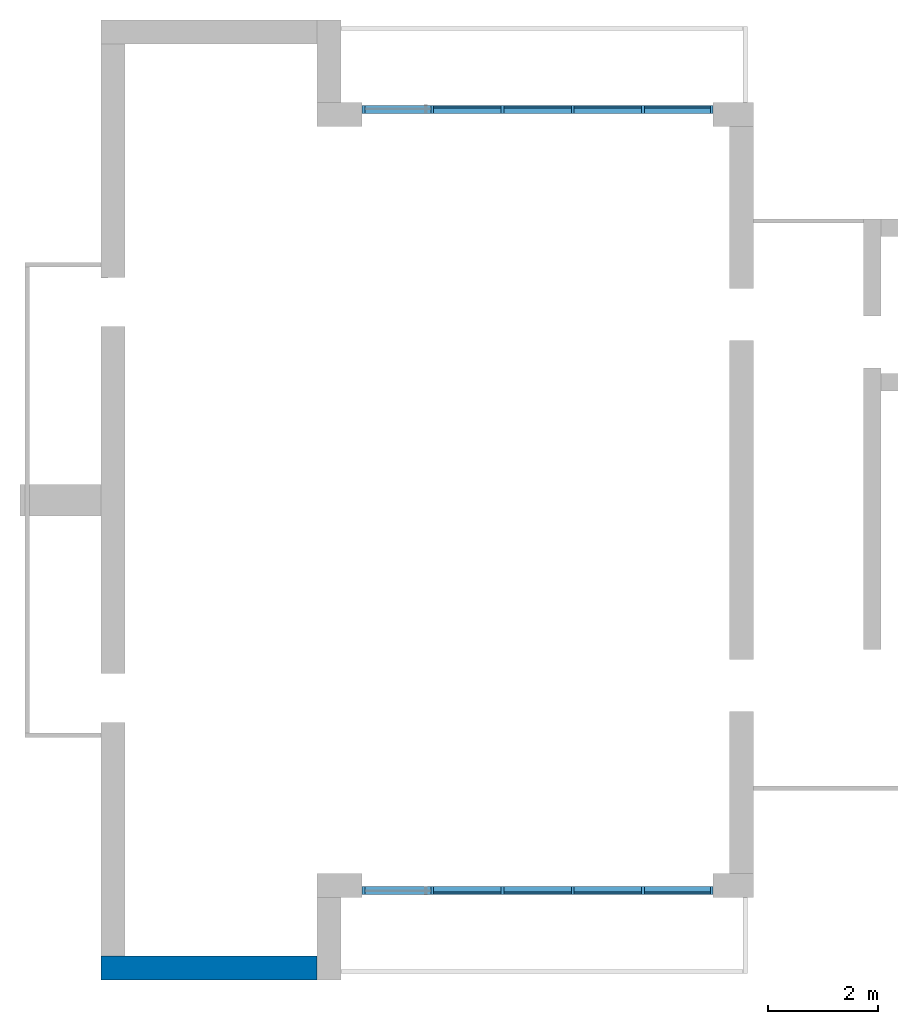
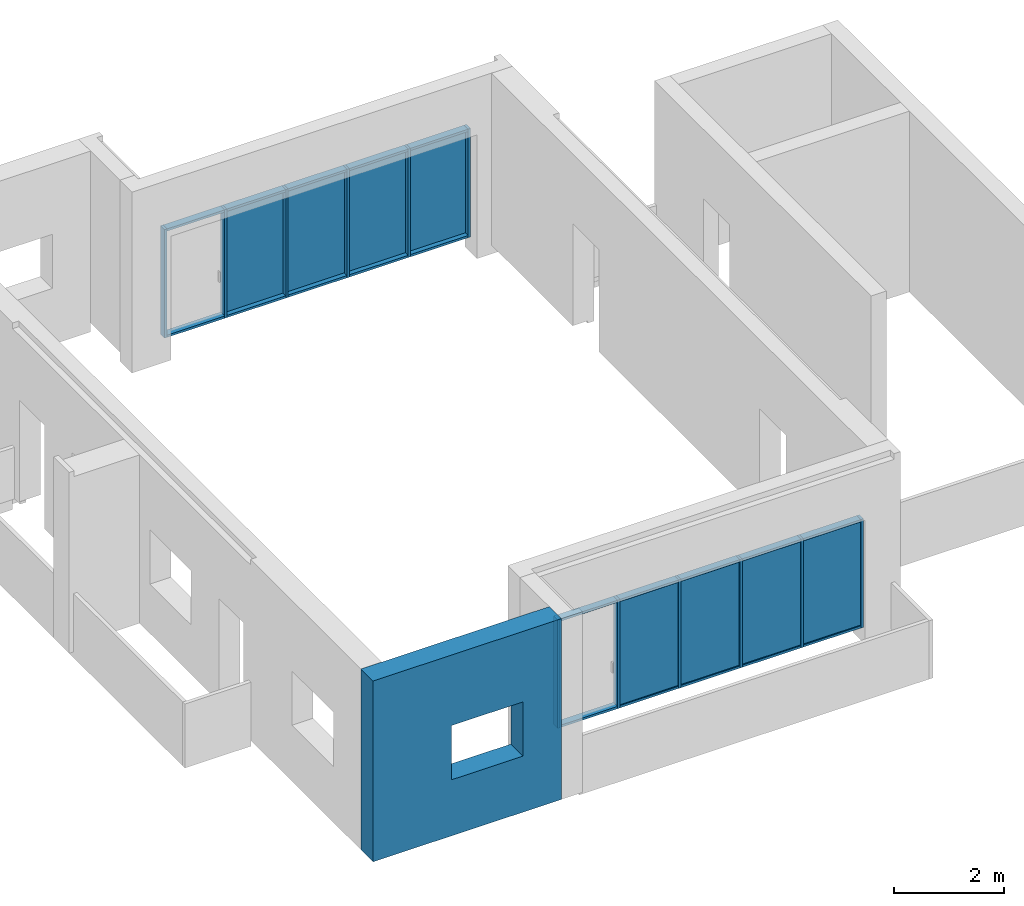
# One storey, part 1 of 4: 32 members, 8 plates, 1 wall, 1 opening, 2 elements without a shape of their own.
"""IFC2X3 building model written with IfcOpenShell, lengths in millimetres."""

from ifc_helpers import new_model, entity, si_unit, converted_unit, derived_unit, direction, frame, frame_2d, origin, origin_2d_with_axis, place, context, subcontext, project, spatial, rectangle, extrude, source, transform, mapped, material, layer, layer_set, layer_usage, type_object, type_shapes, element, aggregate, save


model = new_model("IFC2X3")

# Units and contexts
model_context = context("Model", 3, precision=0.01, world=origin(), true_north=direction((6.12303176911189e-17, 1.0)))
body_context = subcontext(model_context, "Body", "Model", "MODEL_VIEW")
ifc_project = project(units=[si_unit("LENGTHUNIT", "METRE", prefix="MILLI"), si_unit("AREAUNIT", "SQUARE_METRE"), si_unit("VOLUMEUNIT", "CUBIC_METRE"), converted_unit("PLANEANGLEUNIT", "DEGREE", entity("IfcRatioMeasure", 0.0174532925199433), si_unit("PLANEANGLEUNIT", "RADIAN"), dimensions=[0, 0, 0, 0, 0, 0, 0]), si_unit("MASSUNIT", "GRAM", prefix="KILO"), derived_unit("MASSDENSITYUNIT", [(si_unit("MASSUNIT", "GRAM", prefix="KILO"), 1), (si_unit("LENGTHUNIT", "METRE"), -3)]), si_unit("TIMEUNIT", "SECOND"), si_unit("FREQUENCYUNIT", "HERTZ"), si_unit("THERMODYNAMICTEMPERATUREUNIT", "DEGREE_CELSIUS"), derived_unit("THERMALTRANSMITTANCEUNIT", [(si_unit("MASSUNIT", "GRAM", prefix="KILO"), 1), (si_unit("THERMODYNAMICTEMPERATUREUNIT", "KELVIN"), -1), (si_unit("TIMEUNIT", "SECOND"), -3)]), derived_unit("VOLUMETRICFLOWRATEUNIT", [(si_unit("LENGTHUNIT", "METRE"), 3), (si_unit("TIMEUNIT", "SECOND"), -1)]), si_unit("ELECTRICCURRENTUNIT", "AMPERE"), si_unit("ELECTRICVOLTAGEUNIT", "VOLT"), si_unit("POWERUNIT", "WATT"), si_unit("FORCEUNIT", "NEWTON", prefix="KILO"), si_unit("ILLUMINANCEUNIT", "LUX"), si_unit("LUMINOUSFLUXUNIT", "LUMEN"), si_unit("LUMINOUSINTENSITYUNIT", "CANDELA"), derived_unit("USERDEFINED", [(si_unit("MASSUNIT", "GRAM", prefix="KILO"), -1), (si_unit("LENGTHUNIT", "METRE"), -2), (si_unit("TIMEUNIT", "SECOND"), 3), (si_unit("LUMINOUSFLUXUNIT", "LUMEN"), 1)]), derived_unit("LINEARVELOCITYUNIT", [(si_unit("LENGTHUNIT", "METRE"), 1), (si_unit("TIMEUNIT", "SECOND"), -1)]), si_unit("PRESSUREUNIT", "PASCAL"), derived_unit("USERDEFINED", [(si_unit("LENGTHUNIT", "METRE"), -2), (si_unit("MASSUNIT", "GRAM", prefix="KILO"), 1), (si_unit("TIMEUNIT", "SECOND"), -2)])], contexts=[model_context])

# Site, building, storey
site_placement = place(None, origin())
site = spatial("IfcSite", under=ifc_project, at=site_placement, CompositionType="ELEMENT")
building_placement = place(site_placement, origin())
building = spatial("IfcBuilding", under=site, at=building_placement, CompositionType="ELEMENT")
storey_placement = place(building_placement, frame((0.0, 0.0, 8000.0)))
storey = spatial("IfcBuildingStorey", under=building, at=storey_placement, Name="02 Level", CompositionType="ELEMENT", Elevation=8000.0)

# Curtain wall, members
curtain_wall_type = type_object("IfcCurtainWallType", Name="Curtain Wall", PredefinedType="NOTDEFINED")
curtain_wall_1_placement = place(storey_placement, frame((0.0, 0.0, -8000.0)))
curtain_wall_1 = element("IfcCurtainWall", 1, at=curtain_wall_1_placement, inside=storey, type_object=curtain_wall_type, Name="Curtain Wall", ObjectType="Curtain Wall")
ifc_material_1 = material(Name="Aluminium")
member_type_1 = type_object("IfcMemberType", Name="50 x 150mm", PredefinedType="MEMBER")
shared_shape_1 = source(origin(), body_context, "Body", "SweptSolid", [
    extrude(rectangle(XDim=150.0, YDim=50.0, at=origin_2d_with_axis()), frame((-25.0, 0.0, -2400.0), z_axis=(0.0, 0.0, 1.0), x_axis=(0.0, -1.0, 0.0)), (0.0, 0.0, 1.0), 2400.0),
])
type_shapes(member_type_1, [shared_shape_1])
member_1_placement = place(storey_placement, frame((21803.4900708518, -75951.2395851399, 0.0), z_axis=(0.0, 0.0, -1.0), x_axis=(-1.0, 0.0, 0.0)))
member_1 = element("IfcMember", 2, at=member_1_placement, type_object=member_type_1, material=ifc_material_1, Name="Rectangular Mullion:50 x 150mm", ObjectType="Rectangular Mullion:50 x 150mm", context=body_context, shape_type="MappedRepresentation", body=[
    mapped(shared_shape_1, transform((0.0, 0.0, 0.0), scale=1.0)),
])
member_type_2 = type_object("IfcMemberType", Name="50 x 150mm", PredefinedType="MEMBER")
shared_shape_2 = source(origin(), body_context, "Body", "SweptSolid", [
    extrude(rectangle(XDim=150.0, YDim=50.0, at=origin_2d_with_axis()), frame((0.0, 0.0, -2400.0), z_axis=(0.0, 0.0, 1.0), x_axis=(0.0, -1.0, 0.0)), (0.0, 0.0, 1.0), 2400.0),
])
type_shapes(member_type_2, [shared_shape_2])
member_2_placement = place(storey_placement, frame((23083.4900708518, -75951.2395851399, 0.0), z_axis=(0.0, 0.0, -1.0), x_axis=(-1.0, 0.0, 0.0)))
member_2 = element("IfcMember", 3, at=member_2_placement, type_object=member_type_2, material=ifc_material_1, Name="Rectangular Mullion:50 x 150mm", ObjectType="Rectangular Mullion:50 x 150mm", context=body_context, shape_type="MappedRepresentation", body=[
    mapped(shared_shape_2, transform((0.0, 0.0, 0.0), scale=1.0)),
])
member_3_placement = place(storey_placement, frame((24363.4900708518, -75951.2395851399, 0.0), z_axis=(0.0, 0.0, -1.0), x_axis=(-1.0, 0.0, 0.0)))
member_3 = element("IfcMember", 4, at=member_3_placement, type_object=member_type_2, material=ifc_material_1, Name="Rectangular Mullion:50 x 150mm", ObjectType="Rectangular Mullion:50 x 150mm", context=body_context, shape_type="MappedRepresentation", body=[
    mapped(shared_shape_2, transform((0.0, 0.0, 0.0), scale=1.0)),
])
member_4_placement = place(storey_placement, frame((25643.4900708518, -75951.2395851399, 0.0), z_axis=(0.0, 0.0, -1.0), x_axis=(-1.0, 0.0, 0.0)))
member_4 = element("IfcMember", 5, at=member_4_placement, type_object=member_type_2, material=ifc_material_1, Name="Rectangular Mullion:50 x 150mm", ObjectType="Rectangular Mullion:50 x 150mm", context=body_context, shape_type="MappedRepresentation", body=[
    mapped(shared_shape_2, transform((0.0, 0.0, 0.0), scale=1.0)),
])
member_5_placement = place(storey_placement, frame((26923.4900708518, -75951.2395851399, 0.0), z_axis=(0.0, 0.0, -1.0), x_axis=(-1.0, 0.0, 0.0)))
member_5 = element("IfcMember", 6, at=member_5_placement, type_object=member_type_2, material=ifc_material_1, Name="Rectangular Mullion:50 x 150mm", ObjectType="Rectangular Mullion:50 x 150mm", context=body_context, shape_type="MappedRepresentation", body=[
    mapped(shared_shape_2, transform((0.0, 0.0, 0.0), scale=1.0)),
])
member_type_3 = type_object("IfcMemberType", Name="50 x 150mm", PredefinedType="MEMBER")
shared_shape_3 = source(origin(), body_context, "Body", "SweptSolid", [
    extrude(rectangle(XDim=150.0, YDim=50.0, at=origin_2d_with_axis()), frame((-25.0, 0.0, -2400.0), z_axis=(0.0, 0.0, 1.0), x_axis=(0.0, -1.0, 0.0)), (0.0, 0.0, 1.0), 2400.0),
])
type_shapes(member_type_3, [shared_shape_3])
member_6_placement = place(storey_placement, frame((28203.4900708518, -75951.2395851399, 2400.0)))
member_6 = element("IfcMember", 7, at=member_6_placement, type_object=member_type_3, material=ifc_material_1, Name="Rectangular Mullion:50 x 150mm", ObjectType="Rectangular Mullion:50 x 150mm", context=body_context, shape_type="MappedRepresentation", body=[
    mapped(shared_shape_3, transform((0.0, 0.0, 0.0), scale=1.0)),
])
member_type_4 = type_object("IfcMemberType", Name="50 x 150mm", PredefinedType="MEMBER")
shared_shape_4 = source(origin(), body_context, "Body", "SweptSolid", [
    extrude(rectangle(XDim=150.0, YDim=50.0, at=origin_2d_with_axis()), frame((-25.0, 0.0, -1205.0), z_axis=(0.0, 0.0, 1.0), x_axis=(0.0, -1.0, 0.0)), (0.0, 0.0, 1.0), 1205.0),
])
type_shapes(member_type_4, [shared_shape_4])
member_7_placement = place(storey_placement, frame((26948.4900708518, -75951.2395851399, 2400.0), z_axis=(-1.0, 0.0, 0.0), x_axis=(0.0, 0.0, 1.0)))
member_7 = element("IfcMember", 8, at=member_7_placement, type_object=member_type_4, material=ifc_material_1, Name="Rectangular Mullion:50 x 150mm", ObjectType="Rectangular Mullion:50 x 150mm", context=body_context, shape_type="MappedRepresentation", body=[
    mapped(shared_shape_4, transform((0.0, 0.0, 0.0), scale=1.0)),
])
member_8_placement = place(storey_placement, frame((21853.4900708518, -75951.2395851399, 2400.0), z_axis=(-1.0, 0.0, 0.0), x_axis=(0.0, 0.0, 1.0)))
member_8 = element("IfcMember", 9, at=member_8_placement, type_object=member_type_4, material=ifc_material_1, Name="Rectangular Mullion:50 x 150mm", ObjectType="Rectangular Mullion:50 x 150mm", context=body_context, shape_type="MappedRepresentation", body=[
    mapped(shared_shape_4, transform((0.0, 0.0, 0.0), scale=1.0)),
])
member_type_5 = type_object("IfcMemberType", Name="50 x 150mm", PredefinedType="MEMBER")
shared_shape_5 = source(origin(), body_context, "Body", "SweptSolid", [
    extrude(rectangle(XDim=150.0, YDim=50.0, at=origin_2d_with_axis()), frame((-25.0, 0.0, -1230.0), z_axis=(0.0, 0.0, 1.0), x_axis=(0.0, -1.0, 0.0)), (0.0, 0.0, 1.0), 1230.0),
])
type_shapes(member_type_5, [shared_shape_5])
member_9_placement = place(storey_placement, frame((24388.4900708518, -75951.2395851399, 2400.0), z_axis=(-1.0, 0.0, 0.0), x_axis=(0.0, 0.0, 1.0)))
member_9 = element("IfcMember", 10, at=member_9_placement, type_object=member_type_5, material=ifc_material_1, Name="Rectangular Mullion:50 x 150mm", ObjectType="Rectangular Mullion:50 x 150mm", context=body_context, shape_type="MappedRepresentation", body=[
    mapped(shared_shape_5, transform((0.0, 0.0, 0.0), scale=1.0)),
])
member_10_placement = place(storey_placement, frame((25668.4900708518, -75951.2395851399, 2400.0), z_axis=(-1.0, 0.0, 0.0), x_axis=(0.0, 0.0, 1.0)))
member_10 = element("IfcMember", 11, at=member_10_placement, type_object=member_type_5, material=ifc_material_1, Name="Rectangular Mullion:50 x 150mm", ObjectType="Rectangular Mullion:50 x 150mm", context=body_context, shape_type="MappedRepresentation", body=[
    mapped(shared_shape_5, transform((0.0, 0.0, 0.0), scale=1.0)),
])
member_11_placement = place(storey_placement, frame((23108.4900708518, -75951.2395851399, 2400.0), z_axis=(-1.0, 0.0, 0.0), x_axis=(0.0, 0.0, 1.0)))
member_11 = element("IfcMember", 12, at=member_11_placement, type_object=member_type_5, material=ifc_material_1, Name="Rectangular Mullion:50 x 150mm", ObjectType="Rectangular Mullion:50 x 150mm", context=body_context, shape_type="MappedRepresentation", body=[
    mapped(shared_shape_5, transform((0.0, 0.0, 0.0), scale=1.0)),
])
member_type_6 = type_object("IfcMemberType", Name="50 x 150mm", PredefinedType="MEMBER")
shared_shape_6 = source(origin(), body_context, "Body", "SweptSolid", [
    extrude(rectangle(XDim=150.0, YDim=50.0, at=origin_2d_with_axis()), frame((-25.0, 0.0, -1230.0), z_axis=(0.0, 0.0, 1.0), x_axis=(0.0, -1.0, 0.0)), (0.0, 0.0, 1.0), 1230.0),
])
type_shapes(member_type_6, [shared_shape_6])
member_12_placement = place(storey_placement, frame((26898.4900708518, -75951.2395851399, 0.0), z_axis=(1.0, 0.0, 0.0), x_axis=(0.0, 0.0, -1.0)))
member_12 = element("IfcMember", 13, at=member_12_placement, type_object=member_type_6, material=ifc_material_1, Name="Rectangular Mullion:50 x 150mm", ObjectType="Rectangular Mullion:50 x 150mm", context=body_context, shape_type="MappedRepresentation", body=[
    mapped(shared_shape_6, transform((0.0, 0.0, 0.0), scale=1.0)),
])
member_13_placement = place(storey_placement, frame((24338.4900708518, -75951.2395851399, 0.0), z_axis=(1.0, 0.0, 0.0), x_axis=(0.0, 0.0, -1.0)))
member_13 = element("IfcMember", 14, at=member_13_placement, type_object=member_type_6, material=ifc_material_1, Name="Rectangular Mullion:50 x 150mm", ObjectType="Rectangular Mullion:50 x 150mm", context=body_context, shape_type="MappedRepresentation", body=[
    mapped(shared_shape_6, transform((0.0, 0.0, 0.0), scale=1.0)),
])
member_14_placement = place(storey_placement, frame((25618.4900708518, -75951.2395851399, 0.0), z_axis=(1.0, 0.0, 0.0), x_axis=(0.0, 0.0, -1.0)))
member_14 = element("IfcMember", 15, at=member_14_placement, type_object=member_type_6, material=ifc_material_1, Name="Rectangular Mullion:50 x 150mm", ObjectType="Rectangular Mullion:50 x 150mm", context=body_context, shape_type="MappedRepresentation", body=[
    mapped(shared_shape_6, transform((0.0, 0.0, 0.0), scale=1.0)),
])
member_type_7 = type_object("IfcMemberType", Name="50 x 150mm", PredefinedType="MEMBER")
shared_shape_7 = source(origin(), body_context, "Body", "SweptSolid", [
    extrude(rectangle(XDim=150.0, YDim=50.0, at=origin_2d_with_axis()), frame((-25.0, 0.0, -1205.0), z_axis=(0.0, 0.0, 1.0), x_axis=(0.0, -1.0, 0.0)), (0.0, 0.0, 1.0), 1205.0),
])
type_shapes(member_type_7, [shared_shape_7])
member_15_placement = place(storey_placement, frame((23058.4900708518, -75951.2395851399, 0.0), z_axis=(1.0, 0.0, 0.0), x_axis=(0.0, 0.0, -1.0)))
member_15 = element("IfcMember", 16, at=member_15_placement, type_object=member_type_7, material=ifc_material_1, Name="Rectangular Mullion:50 x 150mm", ObjectType="Rectangular Mullion:50 x 150mm", context=body_context, shape_type="MappedRepresentation", body=[
    mapped(shared_shape_7, transform((0.0, 0.0, 0.0), scale=1.0)),
])
member_16_placement = place(storey_placement, frame((28153.4900708518, -75951.2395851399, 0.0), z_axis=(1.0, 0.0, 0.0), x_axis=(0.0, 0.0, -1.0)))
member_16 = element("IfcMember", 17, at=member_16_placement, type_object=member_type_7, material=ifc_material_1, Name="Rectangular Mullion:50 x 150mm", ObjectType="Rectangular Mullion:50 x 150mm", context=body_context, shape_type="MappedRepresentation", body=[
    mapped(shared_shape_7, transform((0.0, 0.0, 0.0), scale=1.0)),
])

curtain_wall_2_placement = place(storey_placement, frame((0.0, 0.0, -8000.0)))
curtain_wall_2 = element("IfcCurtainWall", 18, at=curtain_wall_2_placement, inside=storey, type_object=curtain_wall_type, Name="Curtain Wall", ObjectType="Curtain Wall")
member_type_8 = type_object("IfcMemberType", Name="50 x 150mm", PredefinedType="MEMBER")
shared_shape_8 = source(origin(), body_context, "Body", "SweptSolid", [
    extrude(rectangle(XDim=150.0, YDim=50.0, at=origin_2d_with_axis()), frame((-25.0, 0.0, -2400.0), z_axis=(0.0, 0.0, 1.0), x_axis=(0.0, -1.0, 0.0)), (0.0, 0.0, 1.0), 2400.0),
])
type_shapes(member_type_8, [shared_shape_8])
member_17_placement = place(storey_placement, frame((21803.4900708518, -61711.23958514, 0.0), z_axis=(0.0, 0.0, -1.0), x_axis=(-1.0, 0.0, 0.0)))
member_17 = element("IfcMember", 19, at=member_17_placement, type_object=member_type_8, material=ifc_material_1, Name="Rectangular Mullion:50 x 150mm", ObjectType="Rectangular Mullion:50 x 150mm", context=body_context, shape_type="MappedRepresentation", body=[
    mapped(shared_shape_8, transform((0.0, 0.0, 0.0), scale=1.0)),
])
member_type_9 = type_object("IfcMemberType", Name="50 x 150mm", PredefinedType="MEMBER")
shared_shape_9 = source(origin(), body_context, "Body", "SweptSolid", [
    extrude(rectangle(XDim=150.0, YDim=50.0, at=origin_2d_with_axis()), frame((0.0, 0.0, -2400.0), z_axis=(0.0, 0.0, 1.0), x_axis=(0.0, -1.0, 0.0)), (0.0, 0.0, 1.0), 2400.0),
])
type_shapes(member_type_9, [shared_shape_9])
member_18_placement = place(storey_placement, frame((23083.4900708518, -61711.23958514, 0.0), z_axis=(0.0, 0.0, -1.0), x_axis=(-1.0, 0.0, 0.0)))
member_18 = element("IfcMember", 20, at=member_18_placement, type_object=member_type_9, material=ifc_material_1, Name="Rectangular Mullion:50 x 150mm", ObjectType="Rectangular Mullion:50 x 150mm", context=body_context, shape_type="MappedRepresentation", body=[
    mapped(shared_shape_9, transform((0.0, 0.0, 0.0), scale=1.0)),
])
member_19_placement = place(storey_placement, frame((24363.4900708518, -61711.23958514, 0.0), z_axis=(0.0, 0.0, -1.0), x_axis=(-1.0, 0.0, 0.0)))
member_19 = element("IfcMember", 21, at=member_19_placement, type_object=member_type_9, material=ifc_material_1, Name="Rectangular Mullion:50 x 150mm", ObjectType="Rectangular Mullion:50 x 150mm", context=body_context, shape_type="MappedRepresentation", body=[
    mapped(shared_shape_9, transform((0.0, 0.0, 0.0), scale=1.0)),
])
member_20_placement = place(storey_placement, frame((25643.4900708518, -61711.23958514, 0.0), z_axis=(0.0, 0.0, -1.0), x_axis=(-1.0, 0.0, 0.0)))
member_20 = element("IfcMember", 22, at=member_20_placement, type_object=member_type_9, material=ifc_material_1, Name="Rectangular Mullion:50 x 150mm", ObjectType="Rectangular Mullion:50 x 150mm", context=body_context, shape_type="MappedRepresentation", body=[
    mapped(shared_shape_9, transform((0.0, 0.0, 0.0), scale=1.0)),
])
member_21_placement = place(storey_placement, frame((26923.4900708518, -61711.23958514, 0.0), z_axis=(0.0, 0.0, -1.0), x_axis=(-1.0, 0.0, 0.0)))
member_21 = element("IfcMember", 23, at=member_21_placement, type_object=member_type_9, material=ifc_material_1, Name="Rectangular Mullion:50 x 150mm", ObjectType="Rectangular Mullion:50 x 150mm", context=body_context, shape_type="MappedRepresentation", body=[
    mapped(shared_shape_9, transform((0.0, 0.0, 0.0), scale=1.0)),
])
member_type_10 = type_object("IfcMemberType", Name="50 x 150mm", PredefinedType="MEMBER")
shared_shape_10 = source(origin(), body_context, "Body", "SweptSolid", [
    extrude(rectangle(XDim=150.0, YDim=50.0, at=origin_2d_with_axis()), frame((-25.0, 0.0, -2400.0), z_axis=(0.0, 0.0, 1.0), x_axis=(0.0, -1.0, 0.0)), (0.0, 0.0, 1.0), 2400.0),
])
type_shapes(member_type_10, [shared_shape_10])
member_22_placement = place(storey_placement, frame((28203.4900708519, -61711.23958514, 2400.0)))
member_22 = element("IfcMember", 24, at=member_22_placement, type_object=member_type_10, material=ifc_material_1, Name="Rectangular Mullion:50 x 150mm", ObjectType="Rectangular Mullion:50 x 150mm", context=body_context, shape_type="MappedRepresentation", body=[
    mapped(shared_shape_10, transform((0.0, 0.0, 0.0), scale=1.0)),
])
member_type_11 = type_object("IfcMemberType", Name="50 x 150mm", PredefinedType="MEMBER")
shared_shape_11 = source(origin(), body_context, "Body", "SweptSolid", [
    extrude(rectangle(XDim=150.0, YDim=50.0, at=origin_2d_with_axis()), frame((-25.0, 0.0, -1205.0), z_axis=(0.0, 0.0, 1.0), x_axis=(0.0, -1.0, 0.0)), (0.0, 0.0, 1.0), 1205.0),
])
type_shapes(member_type_11, [shared_shape_11])
member_23_placement = place(storey_placement, frame((26948.4900708518, -61711.23958514, 2400.0), z_axis=(-1.0, 0.0, 0.0), x_axis=(0.0, 0.0, 1.0)))
member_23 = element("IfcMember", 25, at=member_23_placement, type_object=member_type_11, material=ifc_material_1, Name="Rectangular Mullion:50 x 150mm", ObjectType="Rectangular Mullion:50 x 150mm", context=body_context, shape_type="MappedRepresentation", body=[
    mapped(shared_shape_11, transform((0.0, 0.0, 0.0), scale=1.0)),
])
member_24_placement = place(storey_placement, frame((21853.4900708518, -61711.23958514, 2400.0), z_axis=(-1.0, 0.0, 0.0), x_axis=(0.0, 0.0, 1.0)))
member_24 = element("IfcMember", 26, at=member_24_placement, type_object=member_type_11, material=ifc_material_1, Name="Rectangular Mullion:50 x 150mm", ObjectType="Rectangular Mullion:50 x 150mm", context=body_context, shape_type="MappedRepresentation", body=[
    mapped(shared_shape_11, transform((0.0, 0.0, 0.0), scale=1.0)),
])
member_type_12 = type_object("IfcMemberType", Name="50 x 150mm", PredefinedType="MEMBER")
shared_shape_12 = source(origin(), body_context, "Body", "SweptSolid", [
    extrude(rectangle(XDim=150.0, YDim=50.0, at=origin_2d_with_axis()), frame((-25.0, 0.0, -1230.0), z_axis=(0.0, 0.0, 1.0), x_axis=(0.0, -1.0, 0.0)), (0.0, 0.0, 1.0), 1230.0),
])
type_shapes(member_type_12, [shared_shape_12])
member_25_placement = place(storey_placement, frame((24388.4900708518, -61711.23958514, 2400.0), z_axis=(-1.0, 0.0, 0.0), x_axis=(0.0, 0.0, 1.0)))
member_25 = element("IfcMember", 27, at=member_25_placement, type_object=member_type_12, material=ifc_material_1, Name="Rectangular Mullion:50 x 150mm", ObjectType="Rectangular Mullion:50 x 150mm", context=body_context, shape_type="MappedRepresentation", body=[
    mapped(shared_shape_12, transform((0.0, 0.0, 0.0), scale=1.0)),
])
member_26_placement = place(storey_placement, frame((25668.4900708518, -61711.23958514, 2400.0), z_axis=(-1.0, 0.0, 0.0), x_axis=(0.0, 0.0, 1.0)))
member_26 = element("IfcMember", 28, at=member_26_placement, type_object=member_type_12, material=ifc_material_1, Name="Rectangular Mullion:50 x 150mm", ObjectType="Rectangular Mullion:50 x 150mm", context=body_context, shape_type="MappedRepresentation", body=[
    mapped(shared_shape_12, transform((0.0, 0.0, 0.0), scale=1.0)),
])
member_27_placement = place(storey_placement, frame((23108.4900708518, -61711.23958514, 2400.0), z_axis=(-1.0, 0.0, 0.0), x_axis=(0.0, 0.0, 1.0)))
member_27 = element("IfcMember", 29, at=member_27_placement, type_object=member_type_12, material=ifc_material_1, Name="Rectangular Mullion:50 x 150mm", ObjectType="Rectangular Mullion:50 x 150mm", context=body_context, shape_type="MappedRepresentation", body=[
    mapped(shared_shape_12, transform((0.0, 0.0, 0.0), scale=1.0)),
])
member_type_13 = type_object("IfcMemberType", Name="50 x 150mm", PredefinedType="MEMBER")
shared_shape_13 = source(origin(), body_context, "Body", "SweptSolid", [
    extrude(rectangle(XDim=150.0, YDim=50.0, at=origin_2d_with_axis()), frame((-25.0, 0.0, -1230.0), z_axis=(0.0, 0.0, 1.0), x_axis=(0.0, -1.0, 0.0)), (0.0, 0.0, 1.0), 1230.0),
])
type_shapes(member_type_13, [shared_shape_13])
member_28_placement = place(storey_placement, frame((26898.4900708518, -61711.23958514, 0.0), z_axis=(1.0, 0.0, 0.0), x_axis=(0.0, 0.0, -1.0)))
member_28 = element("IfcMember", 30, at=member_28_placement, type_object=member_type_13, material=ifc_material_1, Name="Rectangular Mullion:50 x 150mm", ObjectType="Rectangular Mullion:50 x 150mm", context=body_context, shape_type="MappedRepresentation", body=[
    mapped(shared_shape_13, transform((0.0, 0.0, 0.0), scale=1.0)),
])
member_29_placement = place(storey_placement, frame((24338.4900708518, -61711.23958514, 0.0), z_axis=(1.0, 0.0, 0.0), x_axis=(0.0, 0.0, -1.0)))
member_29 = element("IfcMember", 31, at=member_29_placement, type_object=member_type_13, material=ifc_material_1, Name="Rectangular Mullion:50 x 150mm", ObjectType="Rectangular Mullion:50 x 150mm", context=body_context, shape_type="MappedRepresentation", body=[
    mapped(shared_shape_13, transform((0.0, 0.0, 0.0), scale=1.0)),
])
member_30_placement = place(storey_placement, frame((25618.4900708519, -61711.23958514, 0.0), z_axis=(1.0, 0.0, 0.0), x_axis=(0.0, 0.0, -1.0)))
member_30 = element("IfcMember", 32, at=member_30_placement, type_object=member_type_13, material=ifc_material_1, Name="Rectangular Mullion:50 x 150mm", ObjectType="Rectangular Mullion:50 x 150mm", context=body_context, shape_type="MappedRepresentation", body=[
    mapped(shared_shape_13, transform((0.0, 0.0, 0.0), scale=1.0)),
])
member_type_14 = type_object("IfcMemberType", Name="50 x 150mm", PredefinedType="MEMBER")
shared_shape_14 = source(origin(), body_context, "Body", "SweptSolid", [
    extrude(rectangle(XDim=150.0, YDim=50.0, at=origin_2d_with_axis()), frame((-25.0, 0.0, -1205.0), z_axis=(0.0, 0.0, 1.0), x_axis=(0.0, -1.0, 0.0)), (0.0, 0.0, 1.0), 1205.0),
])
type_shapes(member_type_14, [shared_shape_14])
member_31_placement = place(storey_placement, frame((23058.4900708518, -61711.23958514, 0.0), z_axis=(1.0, 0.0, 0.0), x_axis=(0.0, 0.0, -1.0)))
member_31 = element("IfcMember", 33, at=member_31_placement, type_object=member_type_14, material=ifc_material_1, Name="Rectangular Mullion:50 x 150mm", ObjectType="Rectangular Mullion:50 x 150mm", context=body_context, shape_type="MappedRepresentation", body=[
    mapped(shared_shape_14, transform((0.0, 0.0, 0.0), scale=1.0)),
])
member_32_placement = place(storey_placement, frame((28153.4900708518, -61711.23958514, 0.0), z_axis=(1.0, 0.0, 0.0), x_axis=(0.0, 0.0, -1.0)))
member_32 = element("IfcMember", 34, at=member_32_placement, type_object=member_type_14, material=ifc_material_1, Name="Rectangular Mullion:50 x 150mm", ObjectType="Rectangular Mullion:50 x 150mm", context=body_context, shape_type="MappedRepresentation", body=[
    mapped(shared_shape_14, transform((0.0, 0.0, 0.0), scale=1.0)),
])

# Plate
ifc_material_2 = material()
ifc_layer_1 = layer(ifc_material_2, 25.0)
ifc_layer_set_1 = layer_set([ifc_layer_1], Name="System Panel:Glazed")
ifc_layer_usage_1 = layer_usage(ifc_layer_set_1, "AXIS3", "POSITIVE", 0.121391076115486)
plate_type_1 = type_object("IfcPlateType", Name="Glazed", PredefinedType="CURTAIN_PANEL", material=ifc_layer_set_1)
shared_shape_15 = source(origin(), body_context, "Body", "SweptSolid", [
    extrude(rectangle(XDim=25.0, YDim=1205.0, at=origin_2d_with_axis()), frame((602.499999999999, 12.5, 0.0), z_axis=(0.0, 0.0, 1.0), x_axis=(0.0, 1.0, 0.0)), (0.0, 0.0, 1.0), 2300.0),
])
type_shapes(plate_type_1, [shared_shape_15])
plate_1_placement = place(curtain_wall_1_placement, frame((28153.4900708518, -75975.7395851399, 8050.0), z_axis=(0.0, 0.0, 1.0), x_axis=(-1.0, 0.0, 0.0)))
plate_1 = element("IfcPlate", 35, at=plate_1_placement, type_object=plate_type_1, material=ifc_layer_usage_1, Name="System Panel:Glazed", ObjectType="System Panel:Glazed", context=body_context, shape_type="MappedRepresentation", body=[
    mapped(shared_shape_15, transform((0.0, 0.0, 0.0), scale=1.0)),
])

ifc_layer_usage_2 = layer_usage(ifc_layer_set_1, "AXIS3", "POSITIVE", 0.121391076115486)
plate_type_2 = type_object("IfcPlateType", Name="Glazed", PredefinedType="CURTAIN_PANEL", material=ifc_layer_set_1)
shared_shape_16 = source(origin(), body_context, "Body", "SweptSolid", [
    extrude(rectangle(XDim=25.0, YDim=1230.00000000001, at=origin_2d_with_axis()), frame((615.0, 12.5, 0.0), z_axis=(0.0, 0.0, 1.0), x_axis=(0.0, 1.0, 0.0)), (0.0, 0.0, 1.0), 2300.0),
])
type_shapes(plate_type_2, [shared_shape_16])
plate_2_placement = place(curtain_wall_1_placement, frame((26898.4900708518, -75975.7395851399, 8050.0), z_axis=(0.0, 0.0, 1.0), x_axis=(-1.0, 0.0, 0.0)))
plate_2 = element("IfcPlate", 36, at=plate_2_placement, type_object=plate_type_2, material=ifc_layer_usage_2, Name="System Panel:Glazed", ObjectType="System Panel:Glazed", context=body_context, shape_type="MappedRepresentation", body=[
    mapped(shared_shape_16, transform((0.0, 0.0, 0.0), scale=1.0)),
])

ifc_layer_usage_3 = layer_usage(ifc_layer_set_1, "AXIS3", "POSITIVE", 0.121391076115486)
plate_3_placement = place(curtain_wall_1_placement, frame((25618.4900708518, -75975.7395851399, 8050.0), z_axis=(0.0, 0.0, 1.0), x_axis=(-1.0, 0.0, 0.0)))
plate_3 = element("IfcPlate", 37, at=plate_3_placement, type_object=plate_type_2, material=ifc_layer_usage_3, Name="System Panel:Glazed", ObjectType="System Panel:Glazed", context=body_context, shape_type="MappedRepresentation", body=[
    mapped(shared_shape_16, transform((0.0, 0.0, 0.0), scale=1.0)),
])

ifc_layer_usage_4 = layer_usage(ifc_layer_set_1, "AXIS3", "POSITIVE", 0.121391076115486)
plate_4_placement = place(curtain_wall_1_placement, frame((24338.4900708518, -75975.7395851399, 8050.0), z_axis=(0.0, 0.0, 1.0), x_axis=(-1.0, 0.0, 0.0)))
plate_4 = element("IfcPlate", 38, at=plate_4_placement, type_object=plate_type_2, material=ifc_layer_usage_4, Name="System Panel:Glazed", ObjectType="System Panel:Glazed", context=body_context, shape_type="MappedRepresentation", body=[
    mapped(shared_shape_16, transform((0.0, 0.0, 0.0), scale=1.0)),
])

aggregate(curtain_wall_1, [plate_1, plate_2, plate_3, plate_4, member_1, member_2, member_3, member_4, member_5, member_6, member_7, member_9, member_10, member_11, member_8, member_12, member_13, member_14, member_15, member_16])

ifc_layer_usage_5 = layer_usage(ifc_layer_set_1, "AXIS3", "POSITIVE", 0.121391076115486)
plate_type_3 = type_object("IfcPlateType", Name="Glazed", PredefinedType="CURTAIN_PANEL", material=ifc_layer_set_1)
shared_shape_17 = source(origin(), body_context, "Body", "SweptSolid", [
    extrude(rectangle(XDim=25.0, YDim=1205.0, at=frame_2d((2.66453525910038e-15, 0.0), x_axis=(1.0, 0.0))), frame((602.499999999999, 12.5, 0.0), z_axis=(0.0, 0.0, 1.0), x_axis=(0.0, 1.0, 0.0)), (0.0, 0.0, 1.0), 2300.0),
])
type_shapes(plate_type_3, [shared_shape_17])
plate_5_placement = place(curtain_wall_2_placement, frame((28153.4900708518, -61661.73958514, 8050.0), z_axis=(0.0, 0.0, 1.0), x_axis=(-1.0, 0.0, 0.0)))
plate_5 = element("IfcPlate", 39, at=plate_5_placement, type_object=plate_type_3, material=ifc_layer_usage_5, Name="System Panel:Glazed", ObjectType="System Panel:Glazed", context=body_context, shape_type="MappedRepresentation", body=[
    mapped(shared_shape_17, transform((0.0, 0.0, 0.0), scale=1.0)),
])

ifc_layer_usage_6 = layer_usage(ifc_layer_set_1, "AXIS3", "POSITIVE", 0.121391076115486)
plate_type_4 = type_object("IfcPlateType", Name="Glazed", PredefinedType="CURTAIN_PANEL", material=ifc_layer_set_1)
shared_shape_18 = source(origin(), body_context, "Body", "SweptSolid", [
    extrude(rectangle(XDim=25.0, YDim=1230.0, at=frame_2d((2.66453525910038e-15, 0.0), x_axis=(1.0, 0.0))), frame((615.0, 12.5, 0.0), z_axis=(0.0, 0.0, 1.0), x_axis=(0.0, 1.0, 0.0)), (0.0, 0.0, 1.0), 2300.0),
])
type_shapes(plate_type_4, [shared_shape_18])
plate_6_placement = place(curtain_wall_2_placement, frame((26898.4900708518, -61661.73958514, 8050.0), z_axis=(0.0, 0.0, 1.0), x_axis=(-1.0, 0.0, 0.0)))
plate_6 = element("IfcPlate", 40, at=plate_6_placement, type_object=plate_type_4, material=ifc_layer_usage_6, Name="System Panel:Glazed", ObjectType="System Panel:Glazed", context=body_context, shape_type="MappedRepresentation", body=[
    mapped(shared_shape_18, transform((0.0, 0.0, 0.0), scale=1.0)),
])

ifc_layer_usage_7 = layer_usage(ifc_layer_set_1, "AXIS3", "POSITIVE", 0.121391076115486)
plate_7_placement = place(curtain_wall_2_placement, frame((25618.4900708518, -61661.73958514, 8050.0), z_axis=(0.0, 0.0, 1.0), x_axis=(-1.0, 0.0, 0.0)))
plate_7 = element("IfcPlate", 41, at=plate_7_placement, type_object=plate_type_4, material=ifc_layer_usage_7, Name="System Panel:Glazed", ObjectType="System Panel:Glazed", context=body_context, shape_type="MappedRepresentation", body=[
    mapped(shared_shape_18, transform((0.0, 0.0, 0.0), scale=1.0)),
])

ifc_layer_usage_8 = layer_usage(ifc_layer_set_1, "AXIS3", "POSITIVE", 0.121391076115486)
plate_8_placement = place(curtain_wall_2_placement, frame((24338.4900708518, -61661.73958514, 8050.0), z_axis=(0.0, 0.0, 1.0), x_axis=(-1.0, 0.0, 0.0)))
plate_8 = element("IfcPlate", 42, at=plate_8_placement, type_object=plate_type_4, material=ifc_layer_usage_8, Name="System Panel:Glazed", ObjectType="System Panel:Glazed", context=body_context, shape_type="MappedRepresentation", body=[
    mapped(shared_shape_18, transform((0.0, 0.0, 0.0), scale=1.0)),
])

aggregate(curtain_wall_2, [plate_5, plate_6, plate_7, plate_8, member_17, member_18, member_19, member_20, member_21, member_22, member_23, member_25, member_26, member_27, member_24, member_28, member_29, member_30, member_31, member_32])

# Wall, opening
ifc_material_3 = material(Name="03")
ifc_layer_2 = layer(ifc_material_3, 10.0)
ifc_material_4 = material()
ifc_layer_3 = layer(ifc_material_4, 120.0)
ifc_material_5 = material()
ifc_layer_4 = layer(ifc_material_5, 300.0)
ifc_layer_5 = layer(ifc_material_3, 10.0)
ifc_layer_set_2 = layer_set([ifc_layer_2, ifc_layer_3, ifc_layer_4, ifc_layer_5], Name="Basic Wall:00_fal+12 cm")
ifc_layer_usage_9 = layer_usage(ifc_layer_set_2, "AXIS2", "NEGATIVE", 220.0)
wall_type = type_object("IfcWallType", Name="Basic Wall:00_fal+12 cm", PredefinedType="STANDARD", material=ifc_layer_set_2)
wall_placement = place(storey_placement, frame((20983.4900708518, -77361.2395851399, -340.0), z_axis=(0.0, 0.0, 1.0), x_axis=(-1.0, 0.0, 0.0)))
wall = element("IfcWallStandardCase", 43, at=wall_placement, inside=storey, type_object=wall_type, material=ifc_layer_usage_9, Name="Basic Wall:00_fal+12 cm", ObjectType="Basic Wall:00_fal+12 cm", context=body_context, shape_type="SweptSolid", body=[
    extrude(rectangle(XDim=3940.00000000002, YDim=440.000000000004, at=frame_2d((1970.00000000001, 0.0), x_axis=(-1.0, 0.0))), origin(), (0.0, 0.0, 1.0), 4000.0),
])
opening_placement = place(wall_placement, frame((2300.0, 1744.0, 1240.0), z_axis=(0.0, 0.0, 1.0), x_axis=(-1.0, 0.0, 0.0)))
element("IfcOpeningElement", 44, at=opening_placement, cuts=wall, Name="Basic Wall:00_fal+12 cm", ObjectType="Opening", context=body_context, shape_type="SweptSolid", body=[
    extrude(rectangle(XDim=1200.0, YDim=1500.0, at=frame_2d((-1.08002495835535e-12, 5.11590769747272e-13), x_axis=(0.0, 1.0))), frame((750.0, 3048.0, 600.0), z_axis=(0.0, -1.0, 0.0), x_axis=(1.0, 0.0, 0.0)), (0.0, 0.0, 1.0), 3048.0),
])

save(model, "model.ifc")
